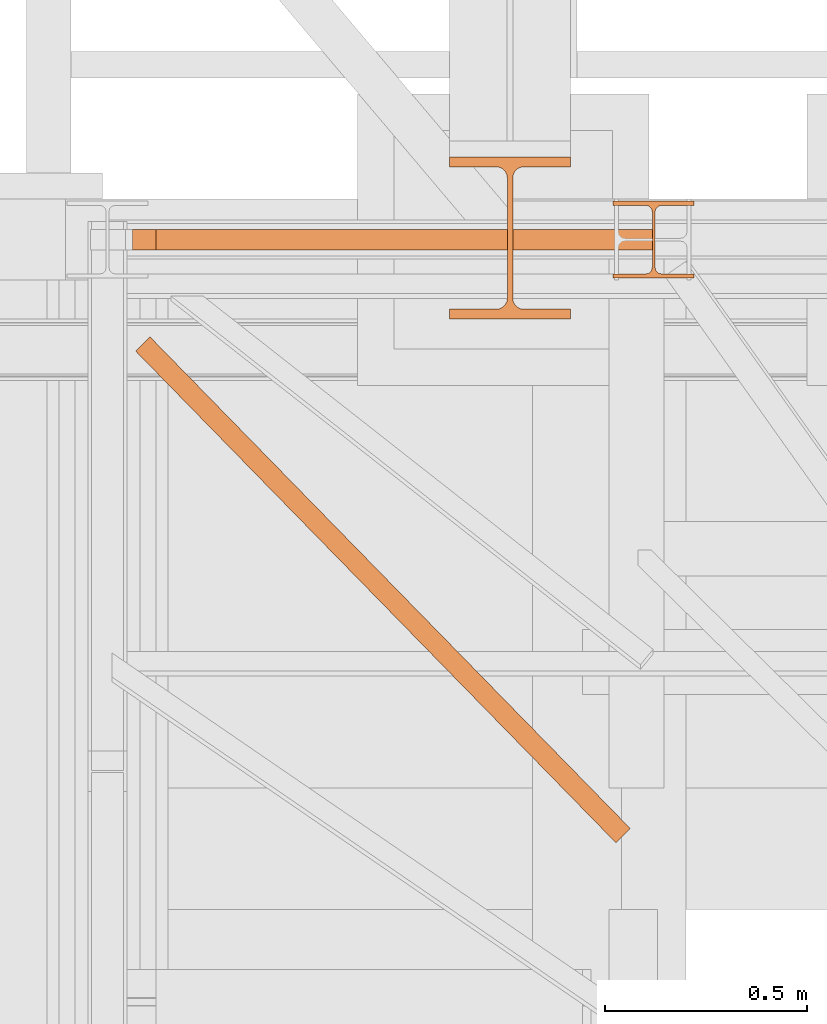
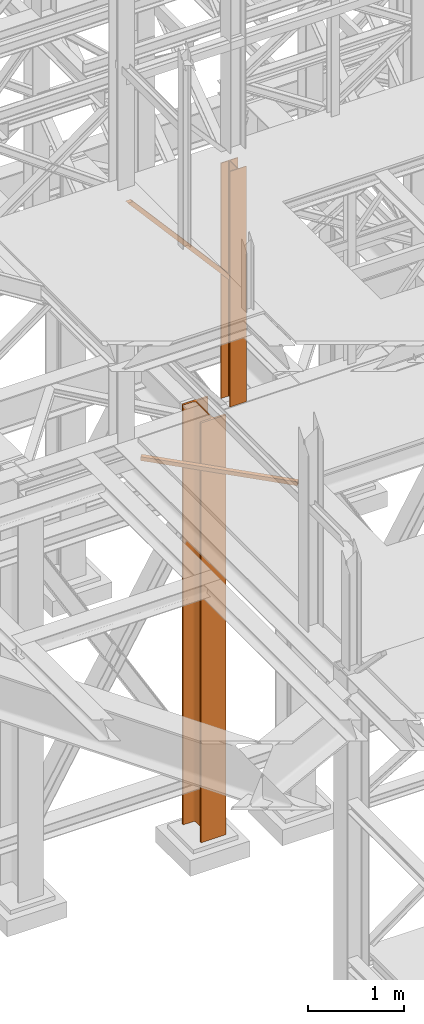
# One storey, part 37 of 208: 4 proxies.
"""IFC2X3 building model written with IfcOpenShell, lengths in millimetres."""

from ifc_helpers import new_model, entity, si_unit, converted_unit, frame, origin, origin_with_axes, place, context, subcontext, project, spatial, faceted_brep, element, save


model = new_model("IFC2X3")

# Units and contexts
model_context = context("Model", 3, precision=1e-05, world=origin())
plan_context = context("Plan", 3, precision=1e-05, world=origin())
body_context = subcontext(model_context, "Body", "Model", "MODEL_VIEW")
ifc_project = project(units=[si_unit("LENGTHUNIT", "METRE", prefix="MILLI"), converted_unit("PLANEANGLEUNIT", "DEGREE", entity("IfcPlaneAngleMeasure", 0.0174532925199433), si_unit("PLANEANGLEUNIT", "RADIAN"), dimensions=[0, 0, 0, 0, 0, 0, 0]), si_unit("AREAUNIT", "SQUARE_METRE"), si_unit("VOLUMEUNIT", "CUBIC_METRE")], contexts=[model_context, plan_context])

# Building, storey
building_placement = place(None, origin())
building = spatial("IfcBuilding", under=ifc_project, at=building_placement, CompositionType="COMPLEX")
storey_placement = place(building_placement, origin_with_axes())
storey = spatial("IfcBuildingStorey", under=building, at=storey_placement, Name="Geschoss", CompositionType="ELEMENT")

# Proxies
proxy_1_placement = place(storey_placement, frame((1267.61752359794, -18753.72161305608, 5124.989999999998), z_axis=(0.0, 0.0, 1.0), x_axis=(1.0, 0.0, 0.0)))
element("IfcBuildingElementProxy", 1, at=proxy_1_placement, inside=storey, context=body_context, shape_type="Brep", body=[
    faceted_brep([(1187.580841812364, 0.00999999999839929, 50.01000000000022), (1187.580841812364, 0.00999999999839929, 0.01000000000021828), (0.009999999999990905, 1215.726637979558, 0.01000000000021828), (0.009999999999990905, 1215.726637979558, 50.01000000000022), (1187.580841812364, 0.00999999999839929, 0.01000000000021828), (1222.861964742378, 35.43939972392036, 0.01000000000021828), (35.29112293001231, 1251.156037703473, 0.01000000000021828), (0.009999999999990905, 1215.726637979558, 0.01000000000021828), (1222.861964742378, 35.43939972392036, 0.01000000000021828), (1222.861964742378, 35.43939972392036, 50.01000000000022), (35.29112293001231, 1251.156037703473, 50.01000000000022), (35.29112293001231, 1251.156037703473, 0.01000000000021828), (1222.861964742378, 35.43939972392036, 50.01000000000022), (1187.580841812364, 0.00999999999839929, 50.01000000000022), (0.009999999999990905, 1215.726637979558, 50.01000000000022), (35.29112293001231, 1251.156037703473, 50.01000000000022), (1187.580841812364, 0.00999999999839929, 50.01000000000022), (1222.861964742378, 35.43939972392036, 50.01000000000022), (1222.861964742378, 35.43939972392036, 0.01000000000021828), (1187.580841812364, 0.00999999999839929, 0.01000000000021828), (1190.403331646766, 2.844351977913902, 4.010000000000218), (1220.039474907978, 32.60504774600486, 4.010000000000218), (1220.039474907978, 32.60504774600486, 46.01000000000022), (1190.403331646766, 2.844351977913902, 46.01000000000022), (0.009999999999990905, 1215.726637979558, 50.01000000000022), (0.009999999999990905, 1215.726637979558, 0.01000000000021828), (35.29112293001231, 1251.156037703473, 0.01000000000021828), (35.29112293001231, 1251.156037703473, 50.01000000000022), (32.46863309561218, 1248.321685725565, 46.01000000000022), (32.46863309561218, 1248.321685725565, 4.010000000000218), (2.832489834401713, 1218.560989957467, 4.010000000000218), (2.832489834401713, 1218.560989957467, 46.01000000000022), (1190.403331646766, 2.844351977913902, 46.01000000000022), (2.832489834401713, 1218.560989957467, 46.01000000000022), (2.832489834401713, 1218.560989957467, 4.010000000000218), (1190.403331646766, 2.844351977913902, 4.010000000000218), (1190.403331646766, 2.844351977913902, 4.010000000000218), (2.832489834401713, 1218.560989957467, 4.010000000000218), (32.46863309561218, 1248.321685725565, 4.010000000000218), (1220.039474907978, 32.60504774600486, 4.010000000000218), (1220.039474907978, 32.60504774600486, 4.010000000000218), (32.46863309561218, 1248.321685725565, 4.010000000000218), (32.46863309561218, 1248.321685725565, 46.01000000000022), (1220.039474907978, 32.60504774600486, 46.01000000000022), (1220.039474907978, 32.60504774600486, 46.01000000000022), (32.46863309561218, 1248.321685725565, 46.01000000000022), (2.832489834401713, 1218.560989957467, 46.01000000000022), (1190.403331646766, 2.844351977913902, 46.01000000000022)], [[[0, 1, 2, 3]], [[4, 5, 6, 7]], [[8, 9, 10, 11]], [[12, 13, 14, 15]], [[16, 17, 18, 19], [20, 21, 22, 23]], [[24, 25, 26, 27], [28, 29, 30, 31]], [[32, 33, 34, 35]], [[36, 37, 38, 39]], [[40, 41, 42, 43]], [[44, 45, 46, 47]]], orient=[[False], [False], [False], [False], [False, False], [False, False], [False], [False], [False], [False]]),
])
proxy_2_placement = place(storey_placement, frame((1259.555429022067, -17287.57439069042, 6812.489999254942), z_axis=(0.0, 0.0, 1.0), x_axis=(1.0, 0.0, 0.0)))
element("IfcBuildingElementProxy", 2, at=proxy_2_placement, inside=storey, context=body_context, shape_type="Brep", body=[
    faceted_brep([(1285.459539439543, 0.01000000000203727, 41.12943667735271), (58.70954427497031, 0.01000000000567525, 1449.577578879704), (58.70954427497031, 50.01000074506374, 1449.577578879704), (1285.459539439544, 50.0100007450601, 41.12943667735271), (1285.459539439544, 50.0100007450601, 41.12943667735271), (58.70954427497031, 50.01000074506374, 1449.577578879704), (58.7095442749694, 50.01000074506374, 1442.509998658894), (0.009999999999990905, 50.01000074506374, 1442.509998658894), (1254.452769993689, 50.0100007450601, 0.01000000000112777), (1285.459539439544, 50.0100007450601, 0.01000000000021828), (1254.452769993689, 50.0100007450601, 0.01000000000112777), (0.009999999999990905, 50.01000074506374, 1442.509998658894), (0.009999999999990905, 0.01000000000567525, 1442.509998658894), (1254.452769993689, 0.01000000000203727, 0.01000000000112777), (1285.459539439544, 0.01000000000203727, 0.01000000000021828), (1254.452769993689, 0.01000000000203727, 0.01000000000112777), (0.009999999999990905, 0.01000000000567525, 1442.509998658894), (58.7095442749694, 0.01000000000567525, 1442.509998658894), (58.70954427497031, 0.01000000000567525, 1449.577578879704), (1285.459539439543, 0.01000000000203727, 41.12943667735271), (58.7095442749694, 0.01000000000567525, 1442.509998658894), (0.009999999999990905, 0.01000000000567525, 1442.509998658894), (0.009999999999990905, 50.01000074506374, 1442.509998658894), (58.7095442749694, 50.01000074506374, 1442.509998658894), (58.7095442749694, 50.01000074506374, 1442.509998658894), (58.70954427497031, 50.01000074506374, 1449.577578879704), (58.70954427497031, 0.01000000000567525, 1449.577578879704), (58.7095442749694, 0.01000000000567525, 1442.509998658894), (1285.459539439544, 50.0100007450601, 0.01000000000021828), (1254.452769993689, 50.0100007450601, 0.01000000000112777), (1254.452769993689, 0.01000000000203727, 0.01000000000112777), (1285.459539439544, 0.01000000000203727, 0.01000000000021828), (1285.459539439544, 50.0100007450601, 41.12943667735271), (1285.459539439544, 50.0100007450601, 0.01000000000021828), (1285.459539439544, 0.01000000000203727, 0.01000000000021828), (1285.459539439543, 0.01000000000203727, 41.12943667735271)], [[[0, 1, 2, 3]], [[4, 5, 6, 7, 8, 9]], [[10, 11, 12, 13]], [[14, 15, 16, 17, 18, 19]], [[20, 21, 22, 23]], [[24, 25, 26, 27]], [[28, 29, 30, 31]], [[32, 33, 34, 35]]], orient=[[False], [False], [False], [False], [False], [False], [False], [False]]),
])
proxy_3_placement = place(storey_placement, frame((2448.25496703855, -17357.57438790132, 5284.990005364414), z_axis=(0.0, 0.0, 1.0), x_axis=(1.0, 0.0, 0.0)))
element("IfcBuildingElementProxy", 3, at=proxy_3_placement, inside=storey, context=body_context, shape_type="Brep", body=[
    faceted_brep([(0.01000000000112777, 190.0100125169738, 3000.009996721743), (200.0100029802334, 190.0100125169738, 3000.009996721743), (200.0100029802334, 180.0100146031364, 3000.009996721743), (121.2600035762798, 180.0100071525558, 3000.009996721743), (111.9441915473353, 178.1454621052726, 3000.009996721743), (105.1245498640847, 171.3258190250381, 3000.009996721743), (103.2600015571725, 162.0100079274162, 3000.009996721743), (103.2600015571725, 28.00999713897545, 3000.009996721743), (105.1245498640847, 18.69418604135353, 3000.009996721743), (111.9441915473353, 11.87454296111901, 3000.009996721743), (121.2600035762798, 10.00999791383583, 3000.009996721743), (200.0100029802334, 10.00999791383583, 3000.009996721743), (200.0100029802334, 0.00999999999839929, 3000.009996721743), (0.01000000000112777, 0.00999999999839929, 3000.009996721743), (0.01000000000112777, 10.00999791383583, 3000.009996721743), (78.75999940395468, 10.00999791383583, 3000.009996721743), (88.07581143289917, 11.87454296111901, 3000.009996721743), (94.89545311614984, 18.69418604135353, 3000.009996721743), (96.76000142306202, 28.00999713897545, 3000.009996721743), (96.76000142306202, 162.0100079274162, 3000.009996721743), (94.89545311614984, 171.3258190250381, 3000.009996721743), (88.07581143289917, 178.1454621052726, 3000.009996721743), (78.75999940395468, 180.0100071525558, 3000.009996721743), (0.01000000000112777, 180.0100146031364, 3000.009996721743), (200.0100029802334, 190.0100125169738, 3000.009996721743), (0.01000000000112777, 190.0100125169738, 3000.009996721743), (0.01000000000021828, 190.0100125169738, 0.01000000000021828), (200.0100029802325, 190.0100125169738, 0.01000000000021828), (200.0100029802334, 180.0100146031364, 3000.009996721743), (200.0100029802334, 190.0100125169738, 3000.009996721743), (200.0100029802325, 190.0100125169738, 0.01000000000021828), (200.0100029802325, 180.0100146031364, 0.01000000000021828), (121.2600035762798, 180.0100071525558, 3000.009996721743), (200.0100029802334, 180.0100146031364, 3000.009996721743), (200.0100029802325, 180.0100146031364, 0.01000000000021828), (121.2600035762789, 180.0100071525558, 0.01000000000021828), (111.9441915473353, 178.1454621052726, 3000.009996721743), (121.2600035762798, 180.0100071525558, 3000.009996721743), (121.2600035762789, 180.0100071525558, 0.01000000000021828), (111.9441915473344, 178.1454621052726, 0.01000000000021828), (105.1245498640847, 171.3258190250381, 3000.009996721743), (111.9441915473353, 178.1454621052726, 3000.009996721743), (111.9441915473344, 178.1454621052726, 0.01000000000021828), (105.1245498640838, 171.3258190250381, 0.01000000000021828), (103.2600015571725, 162.0100079274162, 3000.009996721743), (105.1245498640847, 171.3258190250381, 3000.009996721743), (105.1245498640838, 171.3258190250381, 0.01000000000021828), (103.2600015571716, 162.0100079274162, 0.01000000000021828), (103.2600015571725, 28.00999713897545, 3000.009996721743), (103.2600015571725, 162.0100079274162, 3000.009996721743), (103.2600015571716, 162.0100079274162, 0.01000000000021828), (103.2600015571716, 28.00999713897545, 0.01000000000021828), (105.1245498640847, 18.69418604135353, 3000.009996721743), (103.2600015571725, 28.00999713897545, 3000.009996721743), (103.2600015571716, 28.00999713897545, 0.01000000000021828), (105.1245498640838, 18.69418604135353, 0.01000000000021828), (111.9441915473353, 11.87454296111901, 3000.009996721743), (105.1245498640847, 18.69418604135353, 3000.009996721743), (105.1245498640838, 18.69418604135353, 0.01000000000021828), (111.9441915473344, 11.87454296111901, 0.01000000000021828), (121.2600035762798, 10.00999791383583, 3000.009996721743), (111.9441915473353, 11.87454296111901, 3000.009996721743), (111.9441915473344, 11.87454296111901, 0.01000000000021828), (121.2600035762789, 10.00999791383583, 0.01000000000021828), (200.0100029802334, 10.00999791383583, 3000.009996721743), (121.2600035762798, 10.00999791383583, 3000.009996721743), (121.2600035762789, 10.00999791383583, 0.01000000000021828), (200.0100029802325, 10.00999791383583, 0.01000000000021828), (200.0100029802334, 0.00999999999839929, 3000.009996721743), (200.0100029802334, 10.00999791383583, 3000.009996721743), (200.0100029802325, 10.00999791383583, 0.01000000000021828), (200.0100029802325, 0.00999999999839929, 0.01000000000021828), (0.01000000000112777, 0.00999999999839929, 3000.009996721743), (200.0100029802334, 0.00999999999839929, 3000.009996721743), (200.0100029802325, 0.00999999999839929, 0.01000000000021828), (0.01000000000021828, 0.00999999999839929, 0.01000000000021828), (0.01000000000112777, 10.00999791383583, 3000.009996721743), (0.01000000000112777, 0.00999999999839929, 3000.009996721743), (0.01000000000021828, 0.00999999999839929, 0.01000000000021828), (0.01000000000021828, 10.00999791383583, 0.01000000000021828), (78.75999940395468, 10.00999791383583, 3000.009996721743), (0.01000000000112777, 10.00999791383583, 3000.009996721743), (0.01000000000021828, 10.00999791383583, 0.01000000000021828), (78.75999940395377, 10.00999791383583, 0.01000000000021828), (88.07581143289917, 11.87454296111901, 3000.009996721743), (78.75999940395468, 10.00999791383583, 3000.009996721743), (78.75999940395377, 10.00999791383583, 0.01000000000021828), (88.07581143289826, 11.87454296111901, 0.01000000000021828), (94.89545311614984, 18.69418604135353, 3000.009996721743), (88.07581143289917, 11.87454296111901, 3000.009996721743), (88.07581143289826, 11.87454296111901, 0.01000000000021828), (94.89545311614893, 18.69418604135353, 0.01000000000021828), (96.76000142306202, 28.00999713897545, 3000.009996721743), (94.89545311614984, 18.69418604135353, 3000.009996721743), (94.89545311614893, 18.69418604135353, 0.01000000000021828), (96.76000142306111, 28.00999713897545, 0.01000000000021828), (96.76000142306202, 162.0100079274162, 3000.009996721743), (96.76000142306202, 28.00999713897545, 3000.009996721743), (96.76000142306111, 28.00999713897545, 0.01000000000021828), (96.76000142306111, 162.0100079274162, 0.01000000000021828), (94.89545311614984, 171.3258190250381, 3000.009996721743), (96.76000142306202, 162.0100079274162, 3000.009996721743), (96.76000142306111, 162.0100079274162, 0.01000000000021828), (94.89545311614893, 171.3258190250381, 0.01000000000021828), (88.07581143289917, 178.1454621052726, 3000.009996721743), (94.89545311614984, 171.3258190250381, 3000.009996721743), (94.89545311614893, 171.3258190250381, 0.01000000000021828), (88.07581143289826, 178.1454621052726, 0.01000000000021828), (78.75999940395468, 180.0100071525558, 3000.009996721743), (88.07581143289917, 178.1454621052726, 3000.009996721743), (88.07581143289826, 178.1454621052726, 0.01000000000021828), (78.75999940395377, 180.0100071525558, 0.01000000000021828), (0.01000000000112777, 180.0100146031364, 3000.009996721743), (78.75999940395468, 180.0100071525558, 3000.009996721743), (78.75999940395377, 180.0100071525558, 0.01000000000021828), (0.01000000000021828, 180.0100146031364, 0.01000000000021828), (0.01000000000112777, 190.0100125169738, 3000.009996721743), (0.01000000000112777, 180.0100146031364, 3000.009996721743), (0.01000000000021828, 180.0100146031364, 0.01000000000021828), (0.01000000000021828, 190.0100125169738, 0.01000000000021828), (0.01000000000021828, 190.0100125169738, 0.01000000000021828), (0.01000000000021828, 180.0100146031364, 0.01000000000021828), (78.75999940395377, 180.0100071525558, 0.01000000000021828), (88.07581143289826, 178.1454621052726, 0.01000000000021828), (94.89545311614893, 171.3258190250381, 0.01000000000021828), (96.76000142306111, 162.0100079274162, 0.01000000000021828), (96.76000142306111, 28.00999713897545, 0.01000000000021828), (94.89545311614893, 18.69418604135353, 0.01000000000021828), (88.07581143289826, 11.87454296111901, 0.01000000000021828), (78.75999940395377, 10.00999791383583, 0.01000000000021828), (0.01000000000021828, 10.00999791383583, 0.01000000000021828), (0.01000000000021828, 0.00999999999839929, 0.01000000000021828), (200.0100029802325, 0.00999999999839929, 0.01000000000021828), (200.0100029802325, 10.00999791383583, 0.01000000000021828), (121.2600035762789, 10.00999791383583, 0.01000000000021828), (111.9441915473344, 11.87454296111901, 0.01000000000021828), (105.1245498640838, 18.69418604135353, 0.01000000000021828), (103.2600015571716, 28.00999713897545, 0.01000000000021828), (103.2600015571716, 162.0100079274162, 0.01000000000021828), (105.1245498640838, 171.3258190250381, 0.01000000000021828), (111.9441915473344, 178.1454621052726, 0.01000000000021828), (121.2600035762789, 180.0100071525558, 0.01000000000021828), (200.0100029802325, 180.0100146031364, 0.01000000000021828), (200.0100029802325, 190.0100125169738, 0.01000000000021828)], [[[0, 1, 2, 3, 4, 5, 6, 7, 8, 9, 10, 11, 12, 13, 14, 15, 16, 17, 18, 19, 20, 21, 22, 23]], [[24, 25, 26, 27]], [[28, 29, 30, 31]], [[32, 33, 34, 35]], [[36, 37, 38, 39]], [[40, 41, 42, 43]], [[44, 45, 46, 47]], [[48, 49, 50, 51]], [[52, 53, 54, 55]], [[56, 57, 58, 59]], [[60, 61, 62, 63]], [[64, 65, 66, 67]], [[68, 69, 70, 71]], [[72, 73, 74, 75]], [[76, 77, 78, 79]], [[80, 81, 82, 83]], [[84, 85, 86, 87]], [[88, 89, 90, 91]], [[92, 93, 94, 95]], [[96, 97, 98, 99]], [[100, 101, 102, 103]], [[104, 105, 106, 107]], [[108, 109, 110, 111]], [[112, 113, 114, 115]], [[116, 117, 118, 119]], [[120, 121, 122, 123, 124, 125, 126, 127, 128, 129, 130, 131, 132, 133, 134, 135, 136, 137, 138, 139, 140, 141, 142, 143]]], orient=[[False], [False], [False], [False], [False], [False], [False], [False], [False], [False], [False], [False], [False], [False], [False], [False], [False], [False], [False], [False], [False], [False], [False], [False], [False], [False]]),
])
proxy_4_placement = place(storey_placement, frame((2043.254968528667, -17458.57439531565, -65.01000000000022), z_axis=(0.0, 0.0, 1.0), x_axis=(1.0, 0.0, 0.0)))
element("IfcBuildingElementProxy", 4, at=proxy_4_placement, inside=storey, Name="3D Element", context=body_context, shape_type="Brep", body=[
    faceted_brep([(0.009999999999990905, 400.0099999999984, 5350.010005364416), (300.01, 400.0099999999984, 5350.010005364416), (300.01, 376.0099999999984, 5350.010005364416), (183.76, 376.0099999999984, 5350.010005364416), (175.4165694541391, 374.6884339422577, 5350.010005364416), (167.8898249341985, 370.8534254633996, 5350.010005364416), (161.9165745365979, 364.8801750657985, 5350.010005364416), (157.9269689743871, 356.3774142355105, 5350.010005364416), (156.76, 349.0099999999984, 5350.010005364416), (156.76, 51.0099999999984, 5350.010005364416), (158.0815660577403, 42.66656945413706, 5350.010005364416), (161.9165745365979, 35.13982493419462, 5350.010005364416), (167.8898249341985, 29.16657453659718, 5350.010005364416), (175.4165694541391, 25.33156605773911, 5350.010005364416), (183.76, 24.0099999999984, 5350.010005364416), (300.01, 24.0099999999984, 5350.010005364416), (300.01, 0.00999999999839929, 5350.010005364416), (0.009999999999990905, 0.00999999999839929, 5350.010005364416), (0.009999999999990905, 24.0099999999984, 5350.010005364416), (116.26, 24.0099999999984, 5350.010005364416), (124.6034305458604, 25.33156605773911, 5350.010005364416), (132.1301750658015, 29.16657453659718, 5350.010005364416), (138.1034254634017, 35.13982493419462, 5350.010005364416), (141.9384339422597, 42.66656945413706, 5350.010005364416), (143.26, 51.0099999999984, 5350.010005364416), (143.26, 347.9786887785667, 5350.010005364416), (141.9384339422597, 357.3534305458597, 5350.010005364416), (138.1034254634021, 364.8801750657985, 5350.010005364416), (132.1301750658015, 370.8534254633996, 5350.010005364416), (124.6034305458604, 374.6884339422577, 5350.010005364416), (115.0308095164803, 376.0099999999984, 5350.010005364416), (0.009999999999990905, 376.0099999999984, 5350.010005364416), (300.01, 400.0099999999984, 5350.010005364416), (0.009999999999990905, 400.0099999999984, 5350.010005364416), (0.009999999999990905, 400.0099999999984, 0.01000000000021828), (300.01, 400.0099999999984, 0.01000000000021828), (300.01, 376.0099999999984, 5350.010005364416), (300.01, 400.0099999999984, 5350.010005364416), (300.01, 400.0099999999984, 0.01000000000021828), (300.01, 376.0099999999984, 0.01000000000021828), (183.76, 376.0099999999984, 5350.010005364416), (300.01, 376.0099999999984, 5350.010005364416), (300.01, 376.0099999999984, 0.01000000000021828), (183.76, 376.0099999999984, 0.01000000000021828), (175.4165694541391, 374.6884339422577, 5350.010005364416), (183.76, 376.0099999999984, 5350.010005364416), (183.76, 376.0099999999984, 0.01000000000021828), (175.4165694541391, 374.6884339422577, 0.01000000000021828), (167.8898249341985, 370.8534254633996, 5350.010005364416), (175.4165694541391, 374.6884339422577, 5350.010005364416), (175.4165694541391, 374.6884339422577, 0.01000000000021828), (167.8898249341985, 370.8534254633996, 0.01000000000021828), (161.9165745365979, 364.8801750657985, 5350.010005364416), (167.8898249341985, 370.8534254633996, 5350.010005364416), (167.8898249341985, 370.8534254633996, 0.01000000000021828), (161.9165745365979, 364.8801750657985, 0.01000000000021828), (157.9269689743871, 356.3774142355105, 5350.010005364416), (161.9165745365979, 364.8801750657985, 5350.010005364416), (161.9165745365979, 364.8801750657985, 0.01000000000021828), (157.9269689743871, 356.3774142355105, 0.01000000000021828), (156.76, 349.0099999999984, 5350.010005364416), (157.9269689743871, 356.3774142355105, 5350.010005364416), (157.9269689743871, 356.3774142355105, 0.01000000000021828), (156.76, 349.0099999999984, 0.01000000000021828), (156.76, 51.0099999999984, 5350.010005364416), (156.76, 349.0099999999984, 5350.010005364416), (156.76, 349.0099999999984, 0.01000000000021828), (156.76, 51.0099999999984, 0.01000000000021828), (158.0815660577403, 42.66656945413706, 5350.010005364416), (156.76, 51.0099999999984, 5350.010005364416), (156.76, 51.0099999999984, 0.01000000000021828), (158.0815660577403, 42.66656945413706, 0.01000000000021828), (161.9165745365979, 35.13982493419462, 5350.010005364416), (158.0815660577403, 42.66656945413706, 5350.010005364416), (158.0815660577403, 42.66656945413706, 0.01000000000021828), (161.9165745365979, 35.13982493419462, 0.01000000000021828), (167.8898249341985, 29.16657453659718, 5350.010005364416), (161.9165745365979, 35.13982493419462, 5350.010005364416), (161.9165745365979, 35.13982493419462, 0.01000000000021828), (167.8898249341985, 29.16657453659718, 0.01000000000021828), (175.4165694541391, 25.33156605773911, 5350.010005364416), (167.8898249341985, 29.16657453659718, 5350.010005364416), (167.8898249341985, 29.16657453659718, 0.01000000000021828), (175.4165694541391, 25.33156605773911, 0.01000000000021828), (183.76, 24.0099999999984, 5350.010005364416), (175.4165694541391, 25.33156605773911, 5350.010005364416), (175.4165694541391, 25.33156605773911, 0.01000000000021828), (183.76, 24.0099999999984, 0.01000000000021828), (300.01, 24.0099999999984, 5350.010005364416), (183.76, 24.0099999999984, 5350.010005364416), (183.76, 24.0099999999984, 0.01000000000021828), (300.01, 24.0099999999984, 0.01000000000021828), (300.01, 0.00999999999839929, 5350.010005364416), (300.01, 24.0099999999984, 5350.010005364416), (300.01, 24.0099999999984, 0.01000000000021828), (300.01, 0.00999999999839929, 0.01000000000021828), (0.009999999999990905, 0.00999999999839929, 5350.010005364416), (300.01, 0.00999999999839929, 5350.010005364416), (300.01, 0.00999999999839929, 0.01000000000021828), (0.009999999999990905, 0.00999999999839929, 0.01000000000021828), (0.009999999999990905, 24.0099999999984, 5350.010005364416), (0.009999999999990905, 0.00999999999839929, 5350.010005364416), (0.009999999999990905, 0.00999999999839929, 0.01000000000021828), (0.009999999999990905, 24.0099999999984, 0.01000000000021828), (116.26, 24.0099999999984, 5350.010005364416), (0.009999999999990905, 24.0099999999984, 5350.010005364416), (0.009999999999990905, 24.0099999999984, 0.01000000000021828), (116.26, 24.0099999999984, 0.01000000000021828), (124.6034305458604, 25.33156605773911, 5350.010005364416), (116.26, 24.0099999999984, 5350.010005364416), (116.26, 24.0099999999984, 0.01000000000021828), (124.6034305458604, 25.33156605773911, 0.01000000000021828), (132.1301750658015, 29.16657453659718, 5350.010005364416), (124.6034305458604, 25.33156605773911, 5350.010005364416), (124.6034305458604, 25.33156605773911, 0.01000000000021828), (132.1301750658015, 29.16657453659718, 0.01000000000021828), (138.1034254634017, 35.13982493419462, 5350.010005364416), (132.1301750658015, 29.16657453659718, 5350.010005364416), (132.1301750658015, 29.16657453659718, 0.01000000000021828), (138.1034254634017, 35.13982493419462, 0.01000000000021828), (141.9384339422597, 42.66656945413706, 5350.010005364416), (138.1034254634017, 35.13982493419462, 5350.010005364416), (138.1034254634017, 35.13982493419462, 0.01000000000021828), (141.9384339422597, 42.66656945413706, 0.01000000000021828), (143.26, 51.0099999999984, 5350.010005364416), (141.9384339422597, 42.66656945413706, 5350.010005364416), (141.9384339422597, 42.66656945413706, 0.01000000000021828), (143.26, 51.0099999999984, 0.01000000000021828), (143.26, 347.9786887785667, 5350.010005364416), (143.26, 51.0099999999984, 5350.010005364416), (143.26, 51.0099999999984, 0.01000000000021828), (143.26, 347.9786887785667, 0.01000000000021828), (141.9384339422597, 357.3534305458597, 5350.010005364416), (143.26, 347.9786887785667, 5350.010005364416), (143.26, 347.9786887785667, 0.01000000000021828), (141.9384339422597, 357.3534305458597, 0.01000000000021828), (138.1034254634021, 364.8801750657985, 5350.010005364416), (141.9384339422597, 357.3534305458597, 5350.010005364416), (141.9384339422597, 357.3534305458597, 0.01000000000021828), (138.1034254634021, 364.8801750657985, 0.01000000000021828), (132.1301750658015, 370.8534254633996, 5350.010005364416), (138.1034254634021, 364.8801750657985, 5350.010005364416), (138.1034254634021, 364.8801750657985, 0.01000000000021828), (132.1301750658015, 370.8534254633996, 0.01000000000021828), (124.6034305458604, 374.6884339422577, 5350.010005364416), (132.1301750658015, 370.8534254633996, 5350.010005364416), (132.1301750658015, 370.8534254633996, 0.01000000000021828), (124.6034305458604, 374.6884339422577, 0.01000000000021828), (115.0308095164803, 376.0099999999984, 5350.010005364416), (124.6034305458604, 374.6884339422577, 5350.010005364416), (124.6034305458604, 374.6884339422577, 0.01000000000021828), (115.0308095164803, 376.0099999999984, 0.01000000000021828), (0.009999999999990905, 376.0099999999984, 5350.010005364416), (115.0308095164803, 376.0099999999984, 5350.010005364416), (115.0308095164803, 376.0099999999984, 0.01000000000021828), (0.009999999999990905, 376.0099999999984, 0.01000000000021828), (0.009999999999990905, 400.0099999999984, 5350.010005364416), (0.009999999999990905, 376.0099999999984, 5350.010005364416), (0.009999999999990905, 376.0099999999984, 0.01000000000021828), (0.009999999999990905, 400.0099999999984, 0.01000000000021828), (0.009999999999990905, 400.0099999999984, 0.01000000000021828), (0.009999999999990905, 376.0099999999984, 0.01000000000021828), (115.0308095164803, 376.0099999999984, 0.01000000000021828), (124.6034305458604, 374.6884339422577, 0.01000000000021828), (132.1301750658015, 370.8534254633996, 0.01000000000021828), (138.1034254634021, 364.8801750657985, 0.01000000000021828), (141.9384339422597, 357.3534305458597, 0.01000000000021828), (143.26, 347.9786887785667, 0.01000000000021828), (143.26, 51.0099999999984, 0.01000000000021828), (141.9384339422597, 42.66656945413706, 0.01000000000021828), (138.1034254634017, 35.13982493419462, 0.01000000000021828), (132.1301750658015, 29.16657453659718, 0.01000000000021828), (124.6034305458604, 25.33156605773911, 0.01000000000021828), (116.26, 24.0099999999984, 0.01000000000021828), (0.009999999999990905, 24.0099999999984, 0.01000000000021828), (0.009999999999990905, 0.00999999999839929, 0.01000000000021828), (300.01, 0.00999999999839929, 0.01000000000021828), (300.01, 24.0099999999984, 0.01000000000021828), (183.76, 24.0099999999984, 0.01000000000021828), (175.4165694541391, 25.33156605773911, 0.01000000000021828), (167.8898249341985, 29.16657453659718, 0.01000000000021828), (161.9165745365979, 35.13982493419462, 0.01000000000021828), (158.0815660577403, 42.66656945413706, 0.01000000000021828), (156.76, 51.0099999999984, 0.01000000000021828), (156.76, 349.0099999999984, 0.01000000000021828), (157.9269689743871, 356.3774142355105, 0.01000000000021828), (161.9165745365979, 364.8801750657985, 0.01000000000021828), (167.8898249341985, 370.8534254633996, 0.01000000000021828), (175.4165694541391, 374.6884339422577, 0.01000000000021828), (183.76, 376.0099999999984, 0.01000000000021828), (300.01, 376.0099999999984, 0.01000000000021828), (300.01, 400.0099999999984, 0.01000000000021828)], [[[0, 1, 2, 3, 4, 5, 6, 7, 8, 9, 10, 11, 12, 13, 14, 15, 16, 17, 18, 19, 20, 21, 22, 23, 24, 25, 26, 27, 28, 29, 30, 31]], [[32, 33, 34, 35]], [[36, 37, 38, 39]], [[40, 41, 42, 43]], [[44, 45, 46, 47]], [[48, 49, 50, 51]], [[52, 53, 54, 55]], [[56, 57, 58, 59]], [[60, 61, 62, 63]], [[64, 65, 66, 67]], [[68, 69, 70, 71]], [[72, 73, 74, 75]], [[76, 77, 78, 79]], [[80, 81, 82, 83]], [[84, 85, 86, 87]], [[88, 89, 90, 91]], [[92, 93, 94, 95]], [[96, 97, 98, 99]], [[100, 101, 102, 103]], [[104, 105, 106, 107]], [[108, 109, 110, 111]], [[112, 113, 114, 115]], [[116, 117, 118, 119]], [[120, 121, 122, 123]], [[124, 125, 126, 127]], [[128, 129, 130, 131]], [[132, 133, 134, 135]], [[136, 137, 138, 139]], [[140, 141, 142, 143]], [[144, 145, 146, 147]], [[148, 149, 150, 151]], [[152, 153, 154, 155]], [[156, 157, 158, 159]], [[160, 161, 162, 163, 164, 165, 166, 167, 168, 169, 170, 171, 172, 173, 174, 175, 176, 177, 178, 179, 180, 181, 182, 183, 184, 185, 186, 187, 188, 189, 190, 191]]], orient=[[False], [False], [False], [False], [False], [False], [False], [False], [False], [False], [False], [False], [False], [False], [False], [False], [False], [False], [False], [False], [False], [False], [False], [False], [False], [False], [False], [False], [False], [False], [False], [False], [False], [False]]),
])

save(model, "model.ifc")
